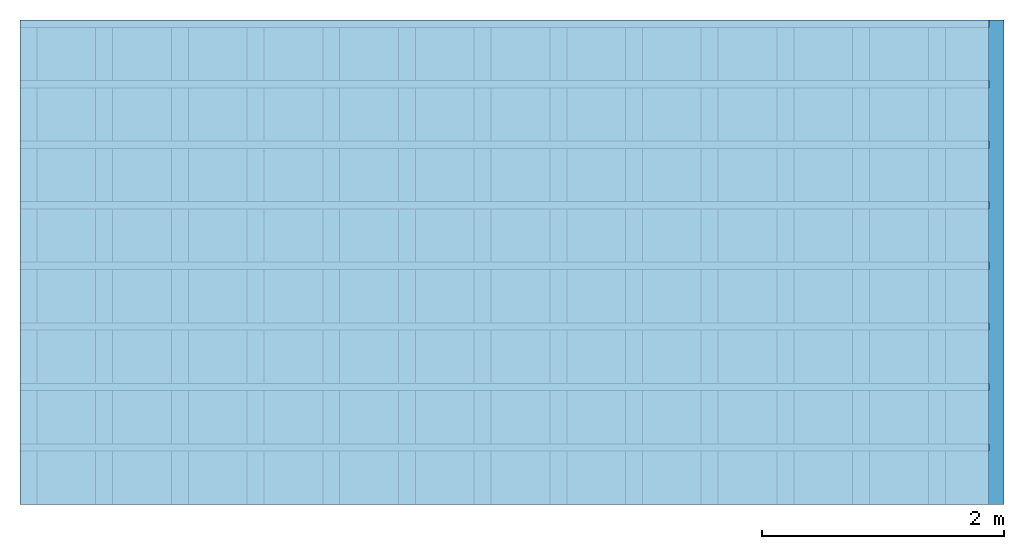
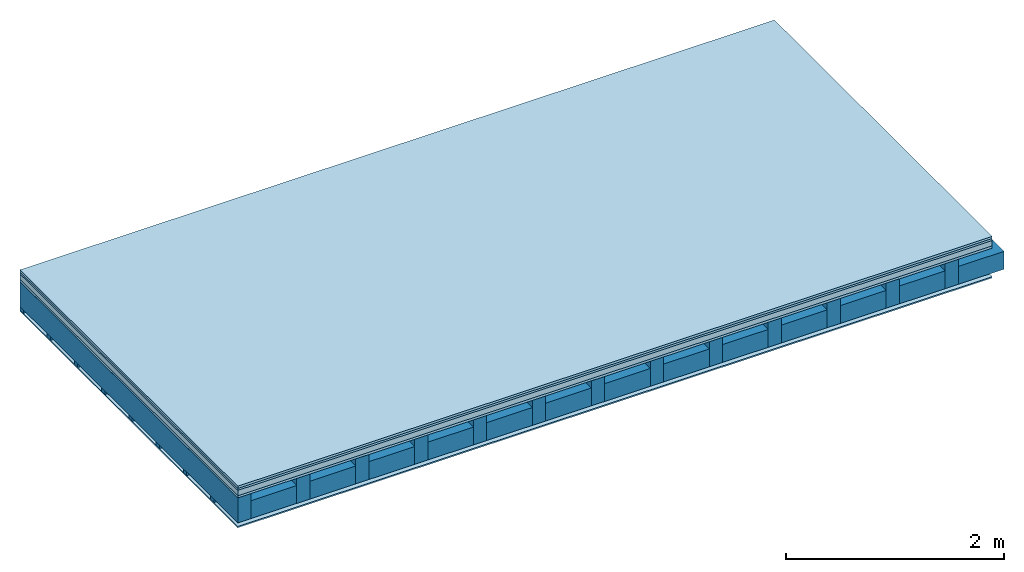
# One storey: 5 plates, 3 members, 1 element without a shape of its own.
"""IFC4 building model written with IfcOpenShell, lengths in metres."""

from ifc_helpers import new_model, si_unit, derived_unit, direction, frame, frame_2d, origin, origin_with_axes, place, context, project, spatial, rectangle, extrude, material, layer, layer_set, type_object, element, aggregate, save


model = new_model("IFC4")

# Units and contexts
plan_context = context("Plan", 3, precision=1e-05, world=origin(), true_north=direction((0.0, 1.0)))
model_context = context("Model", 3, precision=1e-05, world=origin(), true_north=direction((0.0, 1.0)))
ifc_project = project(units=[si_unit("LENGTHUNIT", "METRE"), derived_unit("SOUNDPRESSUREUNIT", [(si_unit("PRESSUREUNIT", "PASCAL", prefix="MICRO"), 0)]), si_unit("ENERGYUNIT", "JOULE", prefix="MEGA"), si_unit("MASSUNIT", "GRAM", prefix="KILO"), derived_unit("THERMALTRANSMITTANCEUNIT", [(si_unit("POWERUNIT", "WATT"), 1), (si_unit("AREAUNIT", "SQUARE_METRE"), -1), (si_unit("THERMODYNAMICTEMPERATUREUNIT", "KELVIN"), -1)]), derived_unit("AREADENSITYUNIT", [(si_unit("MASSUNIT", "GRAM", prefix="KILO"), 1), (si_unit("AREAUNIT", "SQUARE_METRE"), -1)]), derived_unit("USERDEFINED", [(si_unit("ENERGYUNIT", "JOULE", prefix="MEGA"), 1), (si_unit("AREAUNIT", "SQUARE_METRE"), -1)])], contexts=[plan_context, model_context])

# Site, building, storey
site = spatial("IfcSite", under=ifc_project)
building_placement = place(None, origin())
building = spatial("IfcBuilding", under=site, at=building_placement)
storey_placement = place(building_placement, origin())
storey = spatial("IfcBuildingStorey", under=building, at=storey_placement)

# Slab, members, plates
ifc_material_1 = material(Name="Floor heating system Therm38 longitudinal", Category="03.007")
ifc_layer_1 = layer(ifc_material_1, 0.025, Name="On-material")
ifc_material_2 = material(Category="10.009")
ifc_layer_2 = layer(ifc_material_2, 0.022, Name="Impact sound insulation")
ifc_material_3 = material(Category="03.011")
ifc_layer_3 = layer(ifc_material_3, 0.06, Name="on Supporting structure")
ifc_material_4 = material(Category="07.001")
ifc_layer_4 = layer(ifc_material_4, 0.025, Name="Sub-floor")
ifc_material_5 = material(Name="of the art")
ifc_layer_5 = layer(ifc_material_5, 0.0, Name="Bond")
ifc_layer_6 = layer(None, 0.28, Name="Supporting structure")
ifc_layer_7 = layer(ifc_material_5, 0.0, Name="Bond")
ifc_layer_8 = layer(None, 0.04, Name="Battens / profiles")
ifc_material_6 = material(Category="03.007")
ifc_layer_9 = layer(ifc_material_6, 0.015, Name="Ceiling covering 1st layer")
ifc_material_7 = material(Name="Glued joints")
ifc_layer_10 = layer(ifc_material_7, 0.0, Name="Surface / treatment")
ifc_layer_set = layer_set([ifc_layer_1, ifc_layer_2, ifc_layer_3, ifc_layer_4, ifc_layer_5, ifc_layer_6, ifc_layer_7, ifc_layer_8, ifc_layer_9, ifc_layer_10])
slab_type = type_object("IfcSlabType", Name="A0259", PredefinedType="NOTDEFINED", material=ifc_layer_set)
slab_placement = place(None, frame((0.0, 0.0, 0.0), z_axis=(0.0, 0.0, -1.0), x_axis=(1.0, 0.0, 0.0)))
slab = element("IfcSlab", 1, at=slab_placement, inside=storey, type_object=slab_type, material=ifc_layer_set, Name="Slab #1")
ifc_material_8 = material()
member_1_placement = place(slab_placement, origin())
member_1 = element("IfcMember", 2, at=member_1_placement, material=ifc_material_8, Name="Supporting structure", context=plan_context, shape_type="SweptSolid", body=[
    extrude(rectangle(XDim=0.14, YDim=0.28, at=frame_2d((0.07, 0.14), x_axis=(1.0, 0.0))), frame((0.0, 4.0, 0.132), z_axis=(0.0, -1.0, 0.0), x_axis=(1.0, 0.0, 0.0)), (0.0, 0.0, 1.0), 4.0),
    extrude(rectangle(XDim=0.14, YDim=0.28, at=frame_2d((0.07, 0.14), x_axis=(1.0, 0.0))), frame((0.625, 4.0, 0.132), z_axis=(0.0, -1.0, 0.0), x_axis=(1.0, 0.0, 0.0)), (0.0, 0.0, 1.0), 4.0),
    extrude(rectangle(XDim=0.14, YDim=0.28, at=frame_2d((0.07, 0.14), x_axis=(1.0, 0.0))), frame((1.25, 4.0, 0.132), z_axis=(0.0, -1.0, 0.0), x_axis=(1.0, 0.0, 0.0)), (0.0, 0.0, 1.0), 4.0),
    extrude(rectangle(XDim=0.14, YDim=0.28, at=frame_2d((0.07, 0.14), x_axis=(1.0, 0.0))), frame((1.875, 4.0, 0.132), z_axis=(0.0, -1.0, 0.0), x_axis=(1.0, 0.0, 0.0)), (0.0, 0.0, 1.0), 4.0),
    extrude(rectangle(XDim=0.14, YDim=0.28, at=frame_2d((0.07, 0.14), x_axis=(1.0, 0.0))), frame((2.5, 4.0, 0.132), z_axis=(0.0, -1.0, 0.0), x_axis=(1.0, 0.0, 0.0)), (0.0, 0.0, 1.0), 4.0),
    extrude(rectangle(XDim=0.14, YDim=0.28, at=frame_2d((0.07, 0.14), x_axis=(1.0, 0.0))), frame((3.125, 4.0, 0.132), z_axis=(0.0, -1.0, 0.0), x_axis=(1.0, 0.0, 0.0)), (0.0, 0.0, 1.0), 4.0),
    extrude(rectangle(XDim=0.14, YDim=0.28, at=frame_2d((0.07, 0.14), x_axis=(1.0, 0.0))), frame((3.75, 4.0, 0.132), z_axis=(0.0, -1.0, 0.0), x_axis=(1.0, 0.0, 0.0)), (0.0, 0.0, 1.0), 4.0),
    extrude(rectangle(XDim=0.14, YDim=0.28, at=frame_2d((0.07, 0.14), x_axis=(1.0, 0.0))), frame((4.375, 4.0, 0.132), z_axis=(0.0, -1.0, 0.0), x_axis=(1.0, 0.0, 0.0)), (0.0, 0.0, 1.0), 4.0),
    extrude(rectangle(XDim=0.14, YDim=0.28, at=frame_2d((0.07, 0.14), x_axis=(1.0, 0.0))), frame((5.0, 4.0, 0.132), z_axis=(0.0, -1.0, 0.0), x_axis=(1.0, 0.0, 0.0)), (0.0, 0.0, 1.0), 4.0),
    extrude(rectangle(XDim=0.14, YDim=0.28, at=frame_2d((0.07, 0.14), x_axis=(1.0, 0.0))), frame((5.625, 4.0, 0.132), z_axis=(0.0, -1.0, 0.0), x_axis=(1.0, 0.0, 0.0)), (0.0, 0.0, 1.0), 4.0),
    extrude(rectangle(XDim=0.14, YDim=0.28, at=frame_2d((0.07, 0.14), x_axis=(1.0, 0.0))), frame((6.25, 4.0, 0.132), z_axis=(0.0, -1.0, 0.0), x_axis=(1.0, 0.0, 0.0)), (0.0, 0.0, 1.0), 4.0),
    extrude(rectangle(XDim=0.14, YDim=0.28, at=frame_2d((0.07, 0.14), x_axis=(1.0, 0.0))), frame((6.875, 4.0, 0.132), z_axis=(0.0, -1.0, 0.0), x_axis=(1.0, 0.0, 0.0)), (0.0, 0.0, 1.0), 4.0),
    extrude(rectangle(XDim=0.14, YDim=0.28, at=frame_2d((0.07, 0.14), x_axis=(1.0, 0.0))), frame((7.5, 4.0, 0.132), z_axis=(0.0, -1.0, 0.0), x_axis=(1.0, 0.0, 0.0)), (0.0, 0.0, 1.0), 4.0),
])
ifc_material_9 = material()
member_2_placement = place(slab_placement, origin())
member_2 = element("IfcMember", 3, at=member_2_placement, material=ifc_material_9, Name="Cavity", context=plan_context, shape_type="SweptSolid", body=[
    extrude(rectangle(XDim=0.485, YDim=0.2, at=frame_2d((0.2425, 0.1), x_axis=(1.0, 0.0))), frame((0.14, 4.0, 0.212), z_axis=(0.0, -1.0, 0.0), x_axis=(1.0, 0.0, 0.0)), (0.0, 0.0, 1.0), 4.0),
    extrude(rectangle(XDim=0.485, YDim=0.2, at=frame_2d((0.2425, 0.1), x_axis=(1.0, 0.0))), frame((0.765, 4.0, 0.212), z_axis=(0.0, -1.0, 0.0), x_axis=(1.0, 0.0, 0.0)), (0.0, 0.0, 1.0), 4.0),
    extrude(rectangle(XDim=0.485, YDim=0.2, at=frame_2d((0.2425, 0.1), x_axis=(1.0, 0.0))), frame((1.39, 4.0, 0.212), z_axis=(0.0, -1.0, 0.0), x_axis=(1.0, 0.0, 0.0)), (0.0, 0.0, 1.0), 4.0),
    extrude(rectangle(XDim=0.485, YDim=0.2, at=frame_2d((0.2425, 0.1), x_axis=(1.0, 0.0))), frame((2.015, 4.0, 0.212), z_axis=(0.0, -1.0, 0.0), x_axis=(1.0, 0.0, 0.0)), (0.0, 0.0, 1.0), 4.0),
    extrude(rectangle(XDim=0.485, YDim=0.2, at=frame_2d((0.2425, 0.1), x_axis=(1.0, 0.0))), frame((2.64, 4.0, 0.212), z_axis=(0.0, -1.0, 0.0), x_axis=(1.0, 0.0, 0.0)), (0.0, 0.0, 1.0), 4.0),
    extrude(rectangle(XDim=0.485, YDim=0.2, at=frame_2d((0.2425, 0.1), x_axis=(1.0, 0.0))), frame((3.265, 4.0, 0.212), z_axis=(0.0, -1.0, 0.0), x_axis=(1.0, 0.0, 0.0)), (0.0, 0.0, 1.0), 4.0),
    extrude(rectangle(XDim=0.485, YDim=0.2, at=frame_2d((0.2425, 0.1), x_axis=(1.0, 0.0))), frame((3.89, 4.0, 0.212), z_axis=(0.0, -1.0, 0.0), x_axis=(1.0, 0.0, 0.0)), (0.0, 0.0, 1.0), 4.0),
    extrude(rectangle(XDim=0.485, YDim=0.2, at=frame_2d((0.2425, 0.1), x_axis=(1.0, 0.0))), frame((4.515, 4.0, 0.212), z_axis=(0.0, -1.0, 0.0), x_axis=(1.0, 0.0, 0.0)), (0.0, 0.0, 1.0), 4.0),
    extrude(rectangle(XDim=0.485, YDim=0.2, at=frame_2d((0.2425, 0.1), x_axis=(1.0, 0.0))), frame((5.14, 4.0, 0.212), z_axis=(0.0, -1.0, 0.0), x_axis=(1.0, 0.0, 0.0)), (0.0, 0.0, 1.0), 4.0),
    extrude(rectangle(XDim=0.485, YDim=0.2, at=frame_2d((0.2425, 0.1), x_axis=(1.0, 0.0))), frame((5.765, 4.0, 0.212), z_axis=(0.0, -1.0, 0.0), x_axis=(1.0, 0.0, 0.0)), (0.0, 0.0, 1.0), 4.0),
    extrude(rectangle(XDim=0.485, YDim=0.2, at=frame_2d((0.2425, 0.1), x_axis=(1.0, 0.0))), frame((6.39, 4.0, 0.212), z_axis=(0.0, -1.0, 0.0), x_axis=(1.0, 0.0, 0.0)), (0.0, 0.0, 1.0), 4.0),
    extrude(rectangle(XDim=0.485, YDim=0.2, at=frame_2d((0.2425, 0.1), x_axis=(1.0, 0.0))), frame((7.015, 4.0, 0.212), z_axis=(0.0, -1.0, 0.0), x_axis=(1.0, 0.0, 0.0)), (0.0, 0.0, 1.0), 4.0),
    extrude(rectangle(XDim=0.485, YDim=0.2, at=frame_2d((0.2425, 0.1), x_axis=(1.0, 0.0))), frame((7.64, 4.0, 0.212), z_axis=(0.0, -1.0, 0.0), x_axis=(1.0, 0.0, 0.0)), (0.0, 0.0, 1.0), 4.0),
])
ifc_material_10 = material()
member_3_placement = place(slab_placement, origin())
member_3 = element("IfcMember", 4, at=member_3_placement, material=ifc_material_10, Name="Battens / profiles", context=plan_context, shape_type="SweptSolid", body=[
    extrude(rectangle(XDim=0.06, YDim=0.04, at=frame_2d((0.03, 0.02), x_axis=(1.0, 0.0))), frame((0.0, 0.0, 0.412), z_axis=(1.0, 0.0, 0.0), x_axis=(0.0, 1.0, 0.0)), (0.0, 0.0, 1.0), 8.0),
    extrude(rectangle(XDim=0.06, YDim=0.04, at=frame_2d((0.03, 0.02), x_axis=(1.0, 0.0))), frame((0.0, 0.5, 0.412), z_axis=(1.0, 0.0, 0.0), x_axis=(0.0, 1.0, 0.0)), (0.0, 0.0, 1.0), 8.0),
    extrude(rectangle(XDim=0.06, YDim=0.04, at=frame_2d((0.03, 0.02), x_axis=(1.0, 0.0))), frame((0.0, 1.0, 0.412), z_axis=(1.0, 0.0, 0.0), x_axis=(0.0, 1.0, 0.0)), (0.0, 0.0, 1.0), 8.0),
    extrude(rectangle(XDim=0.06, YDim=0.04, at=frame_2d((0.03, 0.02), x_axis=(1.0, 0.0))), frame((0.0, 1.5, 0.412), z_axis=(1.0, 0.0, 0.0), x_axis=(0.0, 1.0, 0.0)), (0.0, 0.0, 1.0), 8.0),
    extrude(rectangle(XDim=0.06, YDim=0.04, at=frame_2d((0.03, 0.02), x_axis=(1.0, 0.0))), frame((0.0, 2.0, 0.412), z_axis=(1.0, 0.0, 0.0), x_axis=(0.0, 1.0, 0.0)), (0.0, 0.0, 1.0), 8.0),
    extrude(rectangle(XDim=0.06, YDim=0.04, at=frame_2d((0.03, 0.02), x_axis=(1.0, 0.0))), frame((0.0, 2.5, 0.412), z_axis=(1.0, 0.0, 0.0), x_axis=(0.0, 1.0, 0.0)), (0.0, 0.0, 1.0), 8.0),
    extrude(rectangle(XDim=0.06, YDim=0.04, at=frame_2d((0.03, 0.02), x_axis=(1.0, 0.0))), frame((0.0, 3.0, 0.412), z_axis=(1.0, 0.0, 0.0), x_axis=(0.0, 1.0, 0.0)), (0.0, 0.0, 1.0), 8.0),
    extrude(rectangle(XDim=0.06, YDim=0.04, at=frame_2d((0.03, 0.02), x_axis=(1.0, 0.0))), frame((0.0, 3.5, 0.412), z_axis=(1.0, 0.0, 0.0), x_axis=(0.0, 1.0, 0.0)), (0.0, 0.0, 1.0), 8.0),
])
plate_1_placement = place(slab_placement, origin())
plate_1 = element("IfcPlate", 5, at=plate_1_placement, material=ifc_material_1, Name="On-material", context=plan_context, shape_type="SweptSolid", body=[
    extrude(rectangle(XDim=8.0, YDim=4.0, at=frame_2d((4.0, 2.0), x_axis=(1.0, 0.0))), origin_with_axes(), (0.0, 0.0, 1.0), 0.025),
])
plate_2_placement = place(slab_placement, origin())
plate_2 = element("IfcPlate", 6, at=plate_2_placement, material=ifc_material_2, Name="Impact sound insulation", context=plan_context, shape_type="SweptSolid", body=[
    extrude(rectangle(XDim=8.0, YDim=4.0, at=frame_2d((4.0, 2.0), x_axis=(1.0, 0.0))), frame((0.0, 0.0, 0.025), z_axis=(0.0, 0.0, 1.0), x_axis=(1.0, 0.0, 0.0)), (0.0, 0.0, 1.0), 0.022),
])
plate_3_placement = place(slab_placement, origin())
plate_3 = element("IfcPlate", 7, at=plate_3_placement, material=ifc_material_3, Name="on Supporting structure", context=plan_context, shape_type="SweptSolid", body=[
    extrude(rectangle(XDim=8.0, YDim=4.0, at=frame_2d((4.0, 2.0), x_axis=(1.0, 0.0))), frame((0.0, 0.0, 0.047), z_axis=(0.0, 0.0, 1.0), x_axis=(1.0, 0.0, 0.0)), (0.0, 0.0, 1.0), 0.06),
])
plate_4_placement = place(slab_placement, origin())
plate_4 = element("IfcPlate", 8, at=plate_4_placement, material=ifc_material_4, Name="Sub-floor", context=plan_context, shape_type="SweptSolid", body=[
    extrude(rectangle(XDim=8.0, YDim=4.0, at=frame_2d((4.0, 2.0), x_axis=(1.0, 0.0))), frame((0.0, 0.0, 0.107), z_axis=(0.0, 0.0, 1.0), x_axis=(1.0, 0.0, 0.0)), (0.0, 0.0, 1.0), 0.025),
])
plate_5_placement = place(slab_placement, origin())
plate_5 = element("IfcPlate", 9, at=plate_5_placement, material=ifc_material_6, Name="Ceiling covering 1st layer", context=plan_context, shape_type="SweptSolid", body=[
    extrude(rectangle(XDim=8.0, YDim=4.0, at=frame_2d((4.0, 2.0), x_axis=(1.0, 0.0))), frame((0.0, 0.0, 0.452), z_axis=(0.0, 0.0, 1.0), x_axis=(1.0, 0.0, 0.0)), (0.0, 0.0, 1.0), 0.015),
])
aggregate(slab, [plate_1, plate_2, plate_3, plate_4, member_1, member_2, member_3, plate_5])

save(model, "model.ifc")
